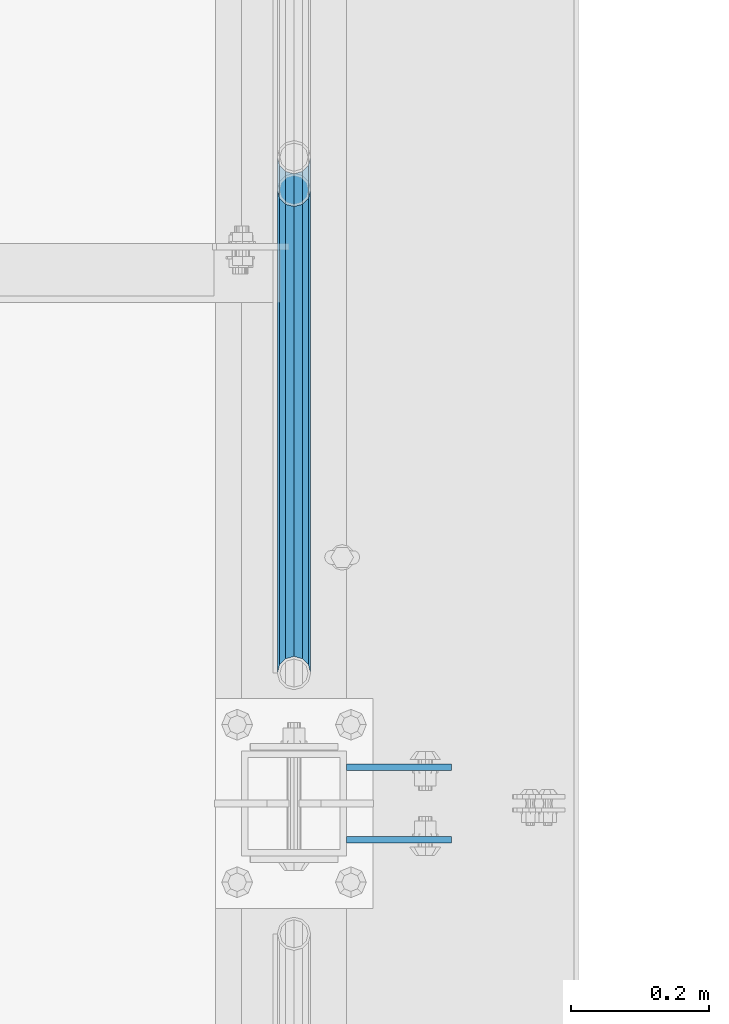
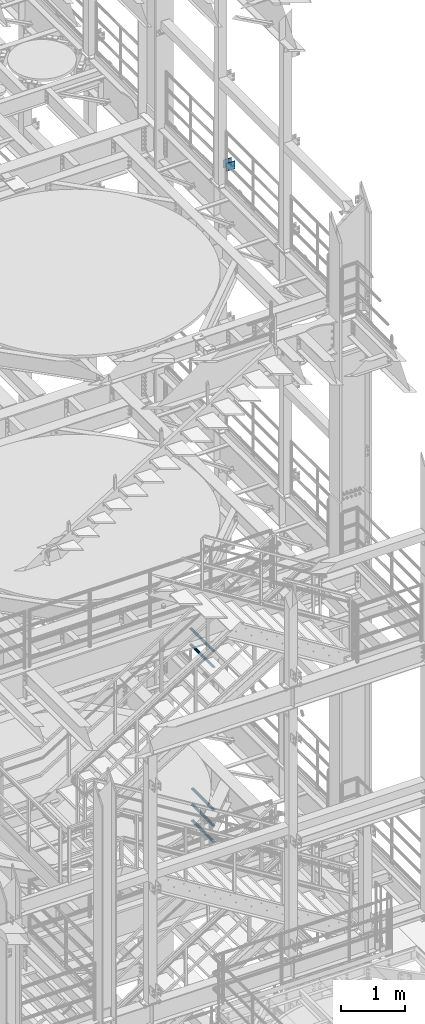
# One storey, part 1268 of 1876: 7 beams, 3 elements without a shape of their own.
"""IFC2X3 building model written with IfcOpenShell, lengths in millimetres."""

from ifc_helpers import new_model, si_unit, frame, origin_with_axes, place, context, subcontext, project, spatial, faceted_brep, material, type_object, element, aggregate, save


model = new_model("IFC2X3")

# Units and contexts
model_context = context("Model", 3, precision=1e-05, world=origin_with_axes())
body_context = subcontext(model_context, "Body", "Model", "MODEL_VIEW")
ifc_project = project(units=[si_unit("LENGTHUNIT", "METRE", prefix="MILLI"), si_unit("AREAUNIT", "SQUARE_METRE"), si_unit("VOLUMEUNIT", "CUBIC_METRE"), si_unit("MASSUNIT", "GRAM", prefix="KILO"), si_unit("TIMEUNIT", "SECOND"), si_unit("PLANEANGLEUNIT", "RADIAN"), si_unit("SOLIDANGLEUNIT", "STERADIAN"), si_unit("THERMODYNAMICTEMPERATUREUNIT", "DEGREE_CELSIUS"), si_unit("LUMINOUSINTENSITYUNIT", "LUMEN")], contexts=[model_context])

# Site, building, storey
site_placement = place(None, origin_with_axes())
site = spatial("IfcSite", under=ifc_project, at=site_placement, CompositionType="ELEMENT")
building_placement = place(site_placement, origin_with_axes())
building = spatial("IfcBuilding", under=site, at=building_placement, Name="Undefined", CompositionType="ELEMENT")
storey_placement = place(building_placement, origin_with_axes())
storey = spatial("IfcBuildingStorey", under=building, at=storey_placement, Name="Undefined", CompositionType="ELEMENT", Elevation=0.0)

# Assembly, beams
assembly_1_placement = place(storey_placement, origin_with_axes())
assembly_1 = element("IfcElementAssembly", 1, at=assembly_1_placement, inside=storey, Name="BEAM", AssemblyPlace="NOTDEFINED", PredefinedType="RIGID_FRAME")
ifc_material_1 = material(Name="STEEL/A36")
beam_type_1 = type_object("IfcBeamType", PredefinedType="NOTDEFINED")
beam_1_placement = place(assembly_1_placement, frame((7696.20000025489, -455.6125, 18275.3), z_axis=(0.0, 0.0, -1.0), x_axis=(1.0, 0.0, 0.0)))
beam_1 = element("IfcBeam", 2, at=beam_1_placement, type_object=beam_type_1, material=ifc_material_1, Name="PLATE", context=body_context, shape_type="Brep", body=[
    faceted_brep([(0.0, 4.76249999999982, -76.1999999999998), (3.63797880709171e-12, 4.76249999999982, 76.1999969482422), (152.399993896484, 4.76250000000073, 76.1999969482422), (152.4, 4.76249999999982, -76.1999999999998), (3.63797880709171e-12, -4.76249999999982, 76.1999969482422), (152.399993896484, -4.76250000000073, 76.1999969482422), (0.0, -4.76249999999982, -76.1999999999998), (152.4, -4.76249999999982, -76.1999999999998)], [[[0, 1, 2, 3]], [[4, 5, 2, 1]], [[4, 6, 7, 5]], [[6, 0, 3, 7]], [[5, 7, 3, 2]], [[6, 4, 1, 0]]]),
])
beam_2_placement = place(assembly_1_placement, frame((7696.20000025489, -560.3875, 18275.3), z_axis=(0.0, 0.0, -1.0), x_axis=(1.0, 0.0, 0.0)))
beam_2 = element("IfcBeam", 3, at=beam_2_placement, type_object=beam_type_1, material=ifc_material_1, Name="PLATE", context=body_context, shape_type="Brep", body=[
    faceted_brep([(0.0, 4.76249999999982, -76.1999999999998), (3.63797880709171e-12, 4.76249999999982, 76.1999969482422), (152.399993896484, 4.76250000000073, 76.1999969482422), (152.4, 4.76249999999982, -76.1999999999998), (3.63797880709171e-12, -4.76249999999982, 76.1999969482422), (152.399993896484, -4.76250000000073, 76.1999969482422), (0.0, -4.76249999999982, -76.1999999999998), (152.4, -4.76249999999982, -76.1999999999998)], [[[0, 1, 2, 3]], [[4, 5, 2, 1]], [[4, 6, 7, 5]], [[6, 0, 3, 7]], [[5, 7, 3, 2]], [[6, 4, 1, 0]]]),
])
aggregate(assembly_1, [beam_1, beam_2])

assembly_2_placement = place(storey_placement, origin_with_axes())
assembly_2 = element("IfcElementAssembly", 4, at=assembly_2_placement, inside=storey, Name="RAIL", AssemblyPlace="NOTDEFINED", PredefinedType="RIGID_FRAME")
ifc_material_2 = material()
beam_type_2 = type_object("IfcBeamType", Name="PIPE1-1/2SCH40", PredefinedType="NOTDEFINED")
beam_3_placement = place(assembly_2_placement, frame((7620.0, -318.770000000001, 8620.125), z_axis=(0.0, 0.0, -1.0), x_axis=(0.0, 1.0, 0.0)))
beam_3 = element("IfcBeam", 5, at=beam_3_placement, type_object=beam_type_2, material=ifc_material_2, Name="RAIL", ObjectType="PIPE1-1/2SCH40", context=body_context, shape_type="Brep", body=[
    faceted_brep([(0.0, 24.1299999999992, 0.0), (12.0650000000064, 20.8971929933177, -12.0649999999987), (12.0650000000064, 20.8971929933177, 12.0649999999987), (12.0650000000064, -20.8971929933177, 12.0649999999987), (12.0650000000064, -20.8971929933177, -12.0649999999987), (0.0, -24.1299999999992, 0.0), (20.8971929933249, -12.0650000000005, 20.8971929933177), (20.8971929933249, -12.0650000000005, 15.8661214311796), (15.2545715621445, -17.7076214311801, 10.2235000000001), (12.5151929933249, -20.4470000000001, 0.0), (15.2545715621445, -17.7076214311801, -10.2235000000001), (20.8971929933249, -12.0650000000005, -15.8661214311796), (20.8971929933249, -12.0650000000005, -20.8971929933177), (24.1300000000063, 0.0, -20.4470000000001), (24.1300000000063, 0.0, -24.130000000001), (21.3906214311868, -10.2235000000001, -17.7076214311819), (21.3906214311868, 10.2235000000001, -17.7076214311819), (20.8971929933249, 12.0650000000005, -15.8661214311796), (20.8971929933249, 12.0650000000005, -20.8971929933177), (15.2545715621445, 17.7076214311801, -10.2235000000001), (12.5151929933249, 20.4470000000001, 0.0), (15.2545715621445, 17.7076214311801, 10.2235000000001), (20.8971929933249, 12.0650000000005, 15.8661214311796), (20.8971929933249, 12.0650000000005, 20.8971929933177), (21.3906214311868, 10.2235000000001, 17.7076214311819), (24.1300000000064, 0.0, 20.4470000000001), (24.1300000000064, 0.0, 24.130000000001), (21.3906214311868, -10.2235000000001, 17.7076214311819), (748.982500000002, 24.1300000000001, 0.0), (736.917500000002, 20.8971929933186, -12.0649999999987), (728.085307006683, 12.0649999999996, -20.8971929933177), (748.982500000002, -24.1300000000001, 0.0), (736.917500000002, -20.8971929933186, -12.0649999999987), (736.917500000002, -20.8971929933186, 12.0649999999987), (728.085307006683, -12.0649999999996, 20.8971929933177), (728.085307006683, -12.0649999999996, -20.8971929933177), (724.852500000002, 0.0, -24.130000000001), (727.591878568821, 10.2235000000001, -17.7076214311819), (724.852500000002, 0.0, -20.4470000000001), (728.085307006683, 12.0649999999996, -15.8661214311796), (728.085307006683, -12.0649999999996, -15.8661214311796), (727.591878568821, -10.2235000000001, -17.7076214311819), (733.727928437864, -17.7076214311801, -10.2235000000001), (736.467307006683, -20.4470000000001, 0.0), (733.727928437864, -17.7076214311801, 10.2235000000001), (728.085307006683, -12.0649999999996, 15.8661214311796), (727.591878568821, -10.2235000000001, 17.7076214311819), (724.852500000002, 0.0, 20.4470000000001), (724.852500000002, 0.0, 24.130000000001), (728.085307006683, 12.0649999999996, 20.8971929933177), (736.917500000002, 20.8971929933186, 12.0649999999987), (728.085307006683, 12.0649999999996, 15.8661214311796), (733.727928437864, 17.7076214311801, 10.2235000000001), (736.467307006683, 20.4470000000001, 0.0), (733.727928437864, 17.7076214311801, -10.2235000000001), (727.591878568821, 10.2235000000001, 17.7076214311819)], [[[0, 1, 2]], [[3, 4, 5]], [[6, 7, 8, 9, 10, 11, 12, 4, 3]], [[13, 14, 12, 11, 15]], [[16, 17, 18, 14, 13]], [[2, 1, 18, 17, 19, 20, 21, 22, 23]], [[23, 22, 24, 25, 26]], [[26, 25, 27, 7, 6]], [[1, 0, 28, 29]], [[18, 1, 29, 30]], [[31, 32, 33]], [[6, 3, 33, 34]], [[3, 5, 31, 33]], [[5, 4, 32, 31]], [[4, 12, 35, 32]], [[12, 14, 36, 35]], [[14, 18, 30, 36]], [[37, 38, 36, 30, 39]], [[40, 35, 36, 38, 41]], [[33, 32, 35, 40, 42, 43, 44, 45, 34]], [[34, 45, 46, 47, 48]], [[26, 6, 34, 48]], [[2, 23, 49, 50]], [[23, 26, 48, 49]], [[0, 2, 50, 28]], [[28, 50, 29]], [[49, 51, 52, 53, 54, 39, 30, 29, 50]], [[48, 47, 55, 51, 49]], [[25, 24, 55, 47]], [[55, 24, 22, 21, 52, 51]], [[21, 20, 53, 52]], [[20, 19, 54, 53]], [[19, 17, 16, 37, 39, 54]], [[16, 13, 38, 37]], [[13, 15, 41, 38]], [[41, 15, 11, 10, 42, 40]], [[10, 9, 43, 42]], [[9, 8, 44, 43]], [[8, 7, 27, 46, 45, 44]], [[27, 25, 47, 46]]]),
])
beam_4_placement = place(assembly_2_placement, frame((7620.0, -318.770000000001, 8924.925), z_axis=(0.0, 0.0, -1.0), x_axis=(0.0, 1.0, 0.0)))
beam_4 = element("IfcBeam", 6, at=beam_4_placement, type_object=beam_type_2, material=ifc_material_2, Name="RAIL", ObjectType="PIPE1-1/2SCH40", context=body_context, shape_type="Brep", body=[
    faceted_brep([(0.0, 24.1299999999992, 0.0), (12.0650000000064, 20.8971929933177, -12.0649999999987), (12.0650000000064, 20.8971929933177, 12.0649999999987), (12.0650000000064, -20.8971929933177, 12.0649999999987), (12.0650000000064, -20.8971929933177, -12.0649999999987), (0.0, -24.1299999999992, 0.0), (20.8971929933249, -12.0650000000005, 20.8971929933177), (20.8971929933249, -12.0650000000005, 15.8661214311796), (15.2545715621445, -17.7076214311801, 10.2235000000001), (12.5151929933249, -20.4470000000001, 0.0), (15.2545715621445, -17.7076214311801, -10.2235000000001), (20.8971929933249, -12.0650000000005, -15.8661214311796), (20.8971929933249, -12.0650000000005, -20.8971929933177), (24.1300000000063, 0.0, -20.4470000000001), (24.1300000000063, 0.0, -24.130000000001), (21.3906214311868, -10.2235000000001, -17.7076214311819), (21.3906214311868, 10.2235000000001, -17.7076214311819), (20.8971929933249, 12.0650000000005, -15.8661214311796), (20.8971929933249, 12.0650000000005, -20.8971929933177), (15.2545715621445, 17.7076214311801, -10.2235000000001), (12.5151929933249, 20.4470000000001, 0.0), (15.2545715621445, 17.7076214311801, 10.2235000000001), (20.8971929933249, 12.0650000000005, 15.8661214311796), (20.8971929933249, 12.0650000000005, 20.8971929933177), (21.3906214311868, 10.2235000000001, 17.7076214311819), (24.1300000000064, 0.0, 20.4470000000001), (24.1300000000064, 0.0, 24.130000000001), (21.3906214311868, -10.2235000000001, 17.7076214311819), (748.982500000002, 24.1300000000001, 0.0), (736.917500000002, 20.8971929933186, -12.0649999999987), (728.085307006683, 12.0649999999996, -20.8971929933177), (748.982500000002, -24.1300000000001, 0.0), (736.917500000002, -20.8971929933186, -12.0649999999987), (736.917500000002, -20.8971929933186, 12.0649999999987), (728.085307006683, -12.0649999999996, 20.8971929933177), (728.085307006683, -12.0649999999996, -20.8971929933177), (724.852500000002, 0.0, -24.130000000001), (727.591878568821, 10.2235000000001, -17.7076214311819), (724.852500000002, 0.0, -20.4470000000001), (728.085307006683, 12.0649999999996, -15.8661214311796), (728.085307006683, -12.0649999999996, -15.8661214311796), (727.591878568821, -10.2235000000001, -17.7076214311819), (733.727928437864, -17.7076214311801, -10.2235000000001), (736.467307006683, -20.4470000000001, 0.0), (733.727928437864, -17.7076214311801, 10.2235000000001), (728.085307006683, -12.0649999999996, 15.8661214311796), (727.591878568821, -10.2235000000001, 17.7076214311819), (724.852500000002, 0.0, 20.4470000000001), (724.852500000002, 0.0, 24.130000000001), (728.085307006683, 12.0649999999996, 20.8971929933177), (736.917500000002, 20.8971929933186, 12.0649999999987), (728.085307006683, 12.0649999999996, 15.8661214311796), (733.727928437864, 17.7076214311801, 10.2235000000001), (736.467307006683, 20.4470000000001, 0.0), (733.727928437864, 17.7076214311801, -10.2235000000001), (727.591878568821, 10.2235000000001, 17.7076214311819)], [[[0, 1, 2]], [[3, 4, 5]], [[6, 7, 8, 9, 10, 11, 12, 4, 3]], [[13, 14, 12, 11, 15]], [[16, 17, 18, 14, 13]], [[2, 1, 18, 17, 19, 20, 21, 22, 23]], [[23, 22, 24, 25, 26]], [[26, 25, 27, 7, 6]], [[1, 0, 28, 29]], [[18, 1, 29, 30]], [[31, 32, 33]], [[6, 3, 33, 34]], [[3, 5, 31, 33]], [[5, 4, 32, 31]], [[4, 12, 35, 32]], [[12, 14, 36, 35]], [[14, 18, 30, 36]], [[37, 38, 36, 30, 39]], [[40, 35, 36, 38, 41]], [[33, 32, 35, 40, 42, 43, 44, 45, 34]], [[34, 45, 46, 47, 48]], [[26, 6, 34, 48]], [[2, 23, 49, 50]], [[23, 26, 48, 49]], [[0, 2, 50, 28]], [[28, 50, 29]], [[49, 51, 52, 53, 54, 39, 30, 29, 50]], [[48, 47, 55, 51, 49]], [[25, 24, 55, 47]], [[55, 24, 22, 21, 52, 51]], [[21, 20, 53, 52]], [[20, 19, 54, 53]], [[19, 17, 16, 37, 39, 54]], [[16, 13, 38, 37]], [[13, 15, 41, 38]], [[41, 15, 11, 10, 42, 40]], [[10, 9, 43, 42]], [[9, 8, 44, 43]], [[8, 7, 27, 46, 45, 44]], [[27, 25, 47, 46]]]),
])
aggregate(assembly_2, [beam_3, beam_4])

assembly_3_placement = place(storey_placement, origin_with_axes())
assembly_3 = element("IfcElementAssembly", 7, at=assembly_3_placement, inside=storey, Name="RAIL", AssemblyPlace="NOTDEFINED", PredefinedType="RIGID_FRAME")
beam_5_placement = place(assembly_3_placement, frame((7620.00000000017, -318.770000000004, 5292.72499999952), z_axis=(0.0, -8.42999999986204e-06, 0.999999999964468), x_axis=(0.0, 0.999999999964468, 8.43000000018809e-06)))
beam_5 = element("IfcBeam", 8, at=beam_5_placement, type_object=beam_type_2, material=ifc_material_2, Name="RAIL", ObjectType="PIPE1-1/2SCH40", context=body_context, shape_type="Brep", body=[
    faceted_brep([(680.442814874983, -12.0649999999996, 20.8971929933068), (680.44277246305, -12.0649999999277, 15.8661214312397), (679.949359549034, -10.2235000000001, 17.7076214311674), (677.210004073059, 2.72848410531878e-12, 20.4469999999883), (677.210035120749, 2.72848410531878e-12, 24.1299999999883), (679.949359548996, 10.2235000000001, 17.7076214311674), (680.44277246305, 12.0650000000714, 15.866121431096), (680.442814874983, 12.0649999999996, 20.8971929933068), (701.33983170571, 24.1300000000001, -1.45519152283669e-11), (689.27493341323, 20.8971929933186, 12.0649999999878), (689.27472999733, 20.8971929933186, -12.0650000000151), (686.085346327061, 17.7076214311801, 10.2234999999873), (688.824638711873, 20.4470000000001, -1.36424205265939e-11), (686.085173958852, 17.7076214311801, -10.2235000000137), (680.442504960242, 12.0650000000714, -15.8661214311223), (680.442462548309, 12.0649999999996, -20.8971929933323), (679.949060998498, 10.2235000000001, -17.7076214311946), (677.20965933664, 0.0, -20.4470000000147), (677.20962828895, 0.0, -24.1300000000147), (680.442504960242, -12.0649999999277, -15.866121431266), (680.442462548309, -12.0649999999996, -20.8971929933323), (679.949060998536, -10.2235000000001, -17.7076214311946), (701.33983170571, -24.1299999999283, -1.45519152283669e-11), (689.27472999733, -20.8971929933186, -12.0650000000151), (689.27493341323, -20.8971929933186, 12.0649999999878), (686.085173958994, -17.7076214311801, -10.2235000000137), (688.824638712016, -20.4470000000001, -1.36424205265939e-11), (686.085346327204, -17.7076214311801, 10.2234999999873), (12.0648982924813, -20.8971929933186, -12.0650000000005), (20.8970168307269, -12.0649999999996, -20.8971929933195), (0.0, 24.1299999999992, 0.0), (12.0648982924813, 20.8971929933186, -12.0650000000005), (12.065101708381, 20.8971929933186, 12.0650000000005), (20.897369157401, 12.0649999999996, 20.8971929933205), (24.1302034167611, 7.18500814400613e-11, 24.1300000000019), (20.8970168307269, 12.0649999999996, -20.8971929933195), (24.1297965849608, 0.0, -24.130000000001), (24.1298276326506, 0.0, -20.447000000001), (20.8970592426604, -12.0649999999277, -15.8661214312533), (21.390472156676, -10.2235000000001, -17.7076214311819), (21.3904721567151, 10.2235000000001, -17.7076214311819), (20.8970592426604, 12.0650000000714, -15.8661214311096), (15.2544853786503, 17.7076214311801, -10.2235000000001), (12.5151929933249, 20.4470000000001, 0.0), (15.2546577468602, 17.7076214311801, 10.223500000001), (20.8973267454676, 12.0650000000714, 15.8661214311096), (21.3907707072121, 10.2235000000001, 17.7076214311819), (24.1301723690713, 7.18500814400613e-11, 20.447000000001), (21.390770707173, -10.2235000000001, 17.7076214311819), (20.8973267454676, -12.0649999999277, 15.8661214312533), (20.897369157401, -12.0649999999996, 20.8971929933205), (12.065101708381, -20.8971929933186, 12.0650000000005), (0.0, -24.1299999999992, 0.0), (15.2546577467156, -17.7076214311801, 10.223500000001), (12.5151929933249, -20.4470000000001, 0.0), (15.2544853785057, -17.7076214311801, -10.2235000000001)], [[[0, 1, 2, 3, 4]], [[4, 3, 5, 6, 7]], [[8, 9, 10]], [[7, 6, 11, 12, 13, 14, 15, 10, 9]], [[16, 17, 18, 15, 14]], [[19, 20, 18, 17, 21]], [[22, 23, 24]], [[24, 23, 20, 19, 25, 26, 27, 1, 0]], [[28, 29, 20, 23]], [[30, 31, 32]], [[33, 34, 4, 7]], [[32, 33, 7, 9]], [[30, 32, 9, 8]], [[31, 30, 8, 10]], [[35, 31, 10, 15]], [[36, 35, 15, 18]], [[29, 36, 18, 20]], [[37, 36, 29, 38, 39]], [[40, 41, 35, 36, 37]], [[32, 31, 35, 41, 42, 43, 44, 45, 33]], [[33, 45, 46, 47, 34]], [[34, 47, 48, 49, 50]], [[34, 50, 0, 4]], [[50, 51, 24, 0]], [[51, 52, 22, 24]], [[52, 28, 23, 22]], [[51, 28, 52]], [[50, 49, 53, 54, 55, 38, 29, 28, 51]], [[55, 54, 26, 25]], [[21, 39, 38, 55, 25, 19]], [[37, 39, 21, 17]], [[40, 37, 17, 16]], [[42, 41, 40, 16, 14, 13]], [[43, 42, 13, 12]], [[44, 43, 12, 11]], [[5, 46, 45, 44, 11, 6]], [[47, 46, 5, 3]], [[48, 47, 3, 2]], [[53, 49, 48, 2, 1, 27]], [[54, 53, 27, 26]]]),
])
beam_6_placement = place(assembly_3_placement, frame((7620.00000000007, 382.569831680697, 5597.53091229414), z_axis=(0.0, 7.91400000045761e-06, -0.999999999968684), x_axis=(0.0, -0.999999999968684, -7.91400000071008e-06)))
beam_6 = element("IfcBeam", 9, at=beam_6_placement, type_object=beam_type_2, material=ifc_material_2, Name="RAIL", ObjectType="PIPE1-1/2SCH40", context=body_context, shape_type="Brep", body=[
    faceted_brep([(0.0, 24.1299999999992, 0.0), (12.0648982924813, 20.8971929933186, -12.0650000000005), (12.065101708381, 20.8971929933186, 12.0650000000005), (12.065101708381, -20.8971929933186, 12.0650000000005), (12.0648982924813, -20.8971929933186, -12.0650000000005), (0.0, -24.1299999999992, 0.0), (20.897369157401, -12.0649999999996, 20.8971929933205), (20.8973267454676, -12.0649999999277, 15.8661214312533), (15.2546577467156, -17.7076214311801, 10.223500000001), (12.5151929933249, -20.4470000000001, 0.0), (15.2544853785057, -17.7076214311801, -10.2235000000001), (20.8970592426604, -12.0649999999277, -15.8661214312533), (20.8970168307269, -12.0649999999996, -20.8971929933195), (24.1298276326506, 0.0, -20.447000000001), (24.1297965849608, 0.0, -24.130000000001), (21.390472156676, -10.2235000000001, -17.7076214311819), (21.3904721567151, 10.2235000000001, -17.7076214311819), (20.8970592426604, 12.0650000000714, -15.8661214311096), (20.8970168307269, 12.0649999999996, -20.8971929933195), (15.2544853786503, 17.7076214311801, -10.2235000000001), (12.5151929933249, 20.4470000000001, 0.0), (15.2546577468602, 17.7076214311801, 10.223500000001), (20.8973267454676, 12.0650000000714, 15.8661214311096), (20.897369157401, 12.0649999999996, 20.8971929933205), (21.3907707072121, 10.2235000000001, 17.7076214311819), (24.1301723690713, 7.18500814400613e-11, 20.447000000001), (24.1302034167611, 7.18500814400613e-11, 24.1300000000019), (21.390770707173, -10.2235000000001, 17.7076214311819), (701.33983170571, 24.1300000000001, -1.45519152283669e-11), (689.27472999733, 20.8971929933186, -12.0650000000151), (680.442462548309, 12.0649999999996, -20.8971929933323), (701.33983170571, -24.1299999999283, -1.45519152283669e-11), (689.27472999733, -20.8971929933186, -12.0650000000151), (689.27493341323, -20.8971929933186, 12.0649999999878), (680.442814874983, -12.0649999999996, 20.8971929933068), (680.442462548309, -12.0649999999996, -20.8971929933323), (677.20962828895, 0.0, -24.1300000000147), (679.949060998498, 10.2235000000001, -17.7076214311946), (677.20965933664, 0.0, -20.4470000000147), (680.442504960242, 12.0650000000714, -15.8661214311223), (680.442504960242, -12.0649999999277, -15.866121431266), (679.949060998536, -10.2235000000001, -17.7076214311946), (686.085173958994, -17.7076214311801, -10.2235000000137), (688.824638712016, -20.4470000000001, -1.36424205265939e-11), (686.085346327204, -17.7076214311801, 10.2234999999873), (680.44277246305, -12.0649999999277, 15.8661214312397), (679.949359549034, -10.2235000000001, 17.7076214311674), (677.210004073059, 2.72848410531878e-12, 20.4469999999883), (677.210035120749, 2.72848410531878e-12, 24.1299999999883), (680.442814874983, 12.0649999999996, 20.8971929933068), (689.27493341323, 20.8971929933186, 12.0649999999878), (680.44277246305, 12.0650000000714, 15.866121431096), (686.085346327061, 17.7076214311801, 10.2234999999873), (688.824638711873, 20.4470000000001, -1.36424205265939e-11), (686.085173958852, 17.7076214311801, -10.2235000000137), (679.949359548996, 10.2235000000001, 17.7076214311674)], [[[0, 1, 2]], [[3, 4, 5]], [[6, 7, 8, 9, 10, 11, 12, 4, 3]], [[13, 14, 12, 11, 15]], [[16, 17, 18, 14, 13]], [[2, 1, 18, 17, 19, 20, 21, 22, 23]], [[23, 22, 24, 25, 26]], [[26, 25, 27, 7, 6]], [[1, 0, 28, 29]], [[18, 1, 29, 30]], [[31, 32, 33]], [[6, 3, 33, 34]], [[3, 5, 31, 33]], [[5, 4, 32, 31]], [[4, 12, 35, 32]], [[12, 14, 36, 35]], [[14, 18, 30, 36]], [[37, 38, 36, 30, 39]], [[40, 35, 36, 38, 41]], [[33, 32, 35, 40, 42, 43, 44, 45, 34]], [[34, 45, 46, 47, 48]], [[26, 6, 34, 48]], [[2, 23, 49, 50]], [[23, 26, 48, 49]], [[0, 2, 50, 28]], [[28, 50, 29]], [[49, 51, 52, 53, 54, 39, 30, 29, 50]], [[48, 47, 55, 51, 49]], [[25, 24, 55, 47]], [[55, 24, 22, 21, 52, 51]], [[21, 20, 53, 52]], [[20, 19, 54, 53]], [[19, 17, 16, 37, 39, 54]], [[16, 13, 38, 37]], [[13, 15, 41, 38]], [[41, 15, 11, 10, 42, 40]], [[10, 9, 43, 42]], [[9, 8, 44, 43]], [[8, 7, 27, 46, 45, 44]], [[27, 25, 47, 46]]]),
])
beam_7_placement = place(assembly_3_placement, frame((7620.00000000007, 382.569831680697, 5902.33091229485), z_axis=(0.0, 7.91400000045761e-06, -0.999999999968684), x_axis=(0.0, -0.999999999968684, -7.91400000071008e-06)))
beam_7 = element("IfcBeam", 10, at=beam_7_placement, type_object=beam_type_2, material=ifc_material_2, Name="RAIL", ObjectType="PIPE1-1/2SCH40", context=body_context, shape_type="Brep", body=[
    faceted_brep([(0.0, 24.1299999999992, 0.0), (12.0648982924813, 20.8971929933186, -12.0650000000005), (12.065101708381, 20.8971929933186, 12.0650000000005), (12.065101708381, -20.8971929933186, 12.0650000000005), (12.0648982924813, -20.8971929933186, -12.0650000000005), (0.0, -24.1299999999992, 0.0), (20.897369157401, -12.0649999999996, 20.8971929933205), (20.8973267454676, -12.0649999999277, 15.8661214312533), (15.2546577467156, -17.7076214311801, 10.223500000001), (12.5151929933249, -20.4470000000001, 0.0), (15.2544853785057, -17.7076214311801, -10.2235000000001), (20.8970592426604, -12.0649999999277, -15.8661214312533), (20.8970168307269, -12.0649999999996, -20.8971929933195), (24.1298276326506, 0.0, -20.447000000001), (24.1297965849608, 0.0, -24.130000000001), (21.390472156676, -10.2235000000001, -17.7076214311819), (21.3904721567151, 10.2235000000001, -17.7076214311819), (20.8970592426604, 12.0650000000714, -15.8661214311096), (20.8970168307269, 12.0649999999996, -20.8971929933195), (15.2544853786503, 17.7076214311801, -10.2235000000001), (12.5151929933249, 20.4470000000001, 0.0), (15.2546577468602, 17.7076214311801, 10.223500000001), (20.8973267454676, 12.0650000000714, 15.8661214311096), (20.897369157401, 12.0649999999996, 20.8971929933205), (21.3907707072121, 10.2235000000001, 17.7076214311819), (24.1301723690713, 7.18500814400613e-11, 20.447000000001), (24.1302034167611, 7.18500814400613e-11, 24.1300000000019), (21.390770707173, -10.2235000000001, 17.7076214311819), (701.33983170571, 24.1300000000001, -1.45519152283669e-11), (689.27472999733, 20.8971929933186, -12.0650000000151), (680.442462548309, 12.0649999999996, -20.8971929933323), (701.33983170571, -24.1299999999283, -1.45519152283669e-11), (689.27472999733, -20.8971929933186, -12.0650000000151), (689.27493341323, -20.8971929933186, 12.0649999999878), (680.442814874983, -12.0649999999996, 20.8971929933068), (680.442462548309, -12.0649999999996, -20.8971929933323), (677.20962828895, 0.0, -24.1300000000147), (679.949060998498, 10.2235000000001, -17.7076214311946), (677.20965933664, 0.0, -20.4470000000147), (680.442504960242, 12.0650000000714, -15.8661214311223), (680.442504960242, -12.0649999999277, -15.866121431266), (679.949060998536, -10.2235000000001, -17.7076214311946), (686.085173958994, -17.7076214311801, -10.2235000000137), (688.824638712016, -20.4470000000001, -1.36424205265939e-11), (686.085346327204, -17.7076214311801, 10.2234999999873), (680.44277246305, -12.0649999999277, 15.8661214312397), (679.949359549034, -10.2235000000001, 17.7076214311674), (677.210004073059, 2.72848410531878e-12, 20.4469999999883), (677.210035120749, 2.72848410531878e-12, 24.1299999999883), (680.442814874983, 12.0649999999996, 20.8971929933068), (689.27493341323, 20.8971929933186, 12.0649999999878), (680.44277246305, 12.0650000000714, 15.866121431096), (686.085346327061, 17.7076214311801, 10.2234999999873), (688.824638711873, 20.4470000000001, -1.36424205265939e-11), (686.085173958852, 17.7076214311801, -10.2235000000137), (679.949359548996, 10.2235000000001, 17.7076214311674)], [[[0, 1, 2]], [[3, 4, 5]], [[6, 7, 8, 9, 10, 11, 12, 4, 3]], [[13, 14, 12, 11, 15]], [[16, 17, 18, 14, 13]], [[2, 1, 18, 17, 19, 20, 21, 22, 23]], [[23, 22, 24, 25, 26]], [[26, 25, 27, 7, 6]], [[1, 0, 28, 29]], [[18, 1, 29, 30]], [[31, 32, 33]], [[6, 3, 33, 34]], [[3, 5, 31, 33]], [[5, 4, 32, 31]], [[4, 12, 35, 32]], [[12, 14, 36, 35]], [[14, 18, 30, 36]], [[37, 38, 36, 30, 39]], [[40, 35, 36, 38, 41]], [[33, 32, 35, 40, 42, 43, 44, 45, 34]], [[34, 45, 46, 47, 48]], [[26, 6, 34, 48]], [[2, 23, 49, 50]], [[23, 26, 48, 49]], [[0, 2, 50, 28]], [[28, 50, 29]], [[49, 51, 52, 53, 54, 39, 30, 29, 50]], [[48, 47, 55, 51, 49]], [[25, 24, 55, 47]], [[55, 24, 22, 21, 52, 51]], [[21, 20, 53, 52]], [[20, 19, 54, 53]], [[19, 17, 16, 37, 39, 54]], [[16, 13, 38, 37]], [[13, 15, 41, 38]], [[41, 15, 11, 10, 42, 40]], [[10, 9, 43, 42]], [[9, 8, 44, 43]], [[8, 7, 27, 46, 45, 44]], [[27, 25, 47, 46]]]),
])
aggregate(assembly_3, [beam_5, beam_6, beam_7])

save(model, "model.ifc")
